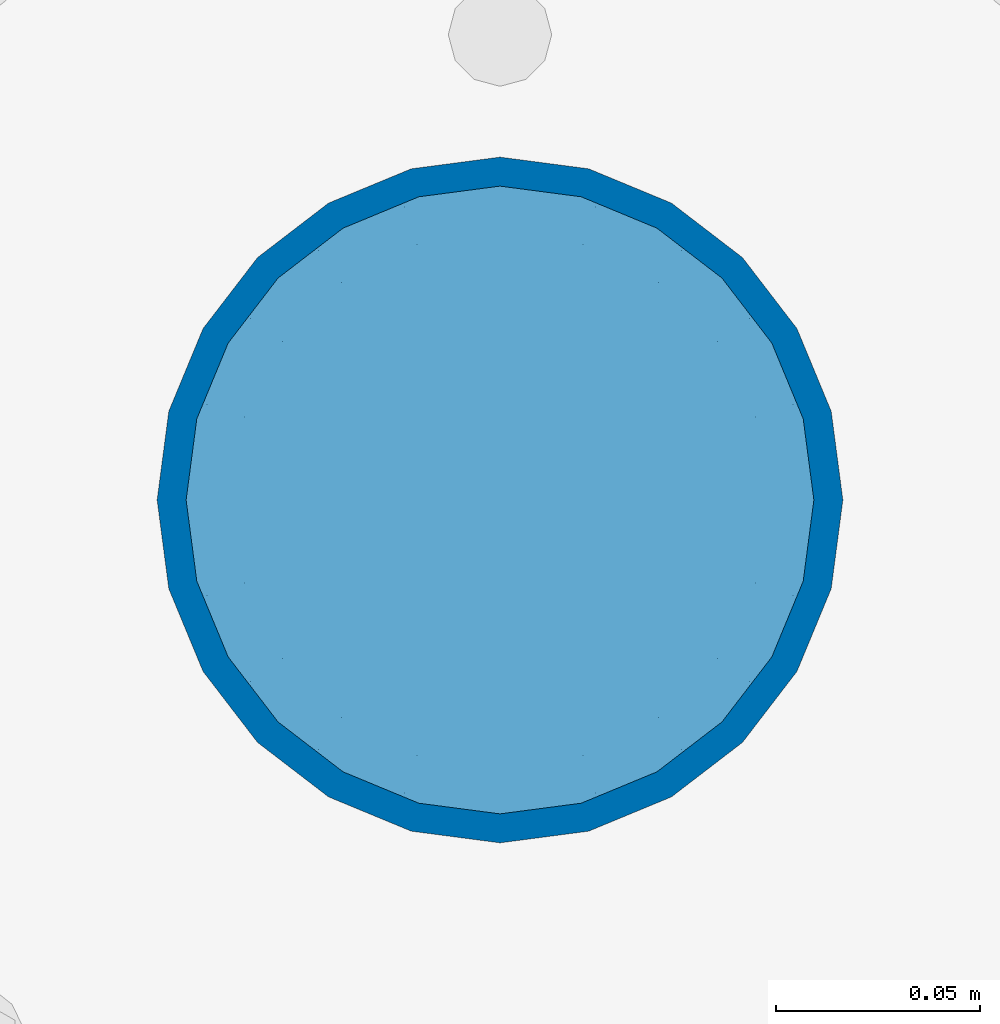
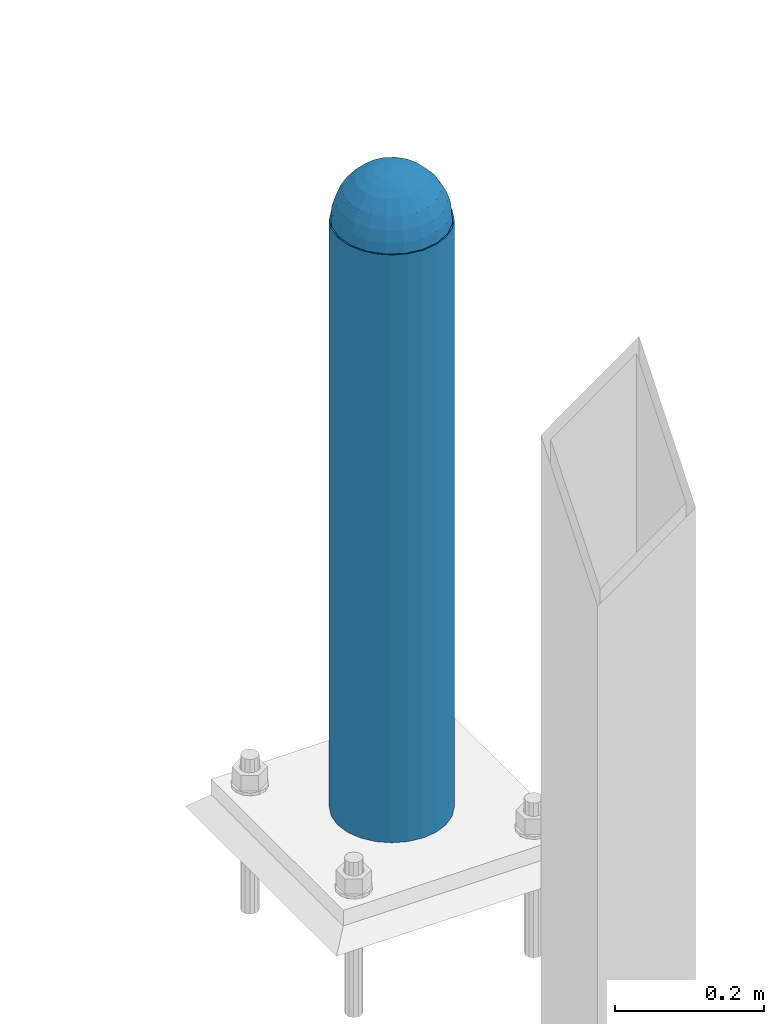
# One storey, part 1591 of 3843: 2 columns, 2 elements without a shape of their own.
"""IFC2X3 building model written with IfcOpenShell, lengths in millimetres."""

import ifcopenshell
import ifcopenshell.guid

model = None  # the IFC model being written
_history = None  # IfcOwnerHistory: only IFC2X3 demands one
_inside = {}  # id of a spatial element -> (the spatial element, [elements in it])
_under = {}  # id of a project, library or spatial element -> (it, [spatial elements below it])
_declared = {}  # id of a project -> (the project, [libraries it declares])
_typed = {}  # id of a type object -> (the type object, [elements of that type])
_made_of = {}  # id of a material, layer set ... -> (it, [elements and type objects made of it])


def new_model(schema):
    """Start an empty IFC model of exactly this schema.

    Asked for "IFC4X3", IfcOpenShell would pick the latest addendum, in which some entities
    have other attributes; the version numbers below select the first issue.
    IFC2X3 requires an IfcOwnerHistory on every rooted entity: one is made here for all.
    """
    global model, _history
    if schema == "IFC4X3":
        model = ifcopenshell.file(schema_version=(4, 3, 0, 0))
    else:
        model = ifcopenshell.file(schema=schema)
    _inside.clear()
    _under.clear()
    _declared.clear()
    _typed.clear()
    _made_of.clear()
    _history = None
    if model.schema == "IFC2X3":
        org = make("IfcOrganization", Name="unknown")
        user = make(
            "IfcPersonAndOrganization",
            ThePerson=make("IfcPerson", FamilyName="unknown"),
            TheOrganization=org,
        )
        app = make(
            "IfcApplication",
            ApplicationDeveloper=org,
            Version="unknown",
            ApplicationFullName="unknown",
            ApplicationIdentifier="unknown",
        )
        _history = make(
            "IfcOwnerHistory",
            OwningUser=user,
            OwningApplication=app,
            ChangeAction="ADDED",
            CreationDate=0,
        )
    return model


def make(cls, **values):
    """One entity of the class cls with the attributes given. An attribute that is None is left unset."""
    return model.create_entity(
        cls, **{name: value for name, value in values.items() if value is not None}
    )


def rooted(cls, **values):
    """An entity with a GlobalId (a new one), such as an element, a storey or a relation."""
    return make(cls, GlobalId=ifcopenshell.guid.new(), OwnerHistory=_history, **values)


def si_unit(unit_type, name, prefix=None):
    """IfcSIUnit, for example si_unit("LENGTHUNIT", "METRE", prefix="MILLI")."""
    return make("IfcSIUnit", UnitType=unit_type, Prefix=prefix, Name=name)


def assignment(units):
    """IfcUnitAssignment: the units of a project."""
    return None if units is None else make("IfcUnitAssignment", Units=units)


def point(xyz):
    """IfcCartesianPoint."""
    return None if xyz is None else make("IfcCartesianPoint", Coordinates=xyz)


def direction(xyz):
    """IfcDirection."""
    return None if xyz is None else make("IfcDirection", DirectionRatios=xyz)


def frame(location, z_axis=None, x_axis=None):
    """IfcAxis2Placement3D, a coordinate frame: its origin and axes. An axis left out is left unset."""
    return make(
        "IfcAxis2Placement3D",
        Location=point(location),
        Axis=direction(z_axis),
        RefDirection=direction(x_axis),
    )


def origin_with_axes():
    """The frame at (0, 0, 0) with the z axis (0, 0, 1) and the x axis (1, 0, 0) written out."""
    return frame((0.0, 0.0, 0.0), z_axis=(0.0, 0.0, 1.0), x_axis=(1.0, 0.0, 0.0))


def place(relative_to, where):
    """IfcLocalPlacement: puts the frame where relative to a parent placement (None: the world)."""
    return make(
        "IfcLocalPlacement", PlacementRelTo=relative_to, RelativePlacement=where
    )


def context(
    kind, dimensions, precision=None, world=None, true_north=None, identifier=None
):
    """IfcGeometricRepresentationContext, for example the 3D "Model" context."""
    return make(
        "IfcGeometricRepresentationContext",
        ContextIdentifier=identifier,
        ContextType=kind,
        CoordinateSpaceDimension=dimensions,
        Precision=precision,
        WorldCoordinateSystem=world,
        TrueNorth=true_north,
    )


def subcontext(parent, identifier, kind, view, scale=None):
    """IfcGeometricRepresentationSubContext, for example "Body" below "Model"."""
    return make(
        "IfcGeometricRepresentationSubContext",
        ContextIdentifier=identifier,
        ContextType=kind,
        ParentContext=parent,
        TargetScale=scale,
        TargetView=view,
    )


def project(units=None, contexts=None):
    """IfcProject with its units and contexts."""
    return rooted(
        "IfcProject",
        Name="project",
        RepresentationContexts=contexts,
        UnitsInContext=assignment(units),
    )


def spatial(cls, under=None, at=None, **own):
    """A site, building, storey or space (cls), placed at a placement, below another one or the project."""
    s = rooted(cls, ObjectPlacement=at, **own)
    if under is not None:
        _under.setdefault(under.id(), (under, []))[1].append(s)
    return s


def faces_of(points, faces, orient=None, outer=None):
    """IfcFace entities. A face is a list of loops; a loop is a list of indices into points, from 0.

    orient and outer hold one flag for each loop. By default every Orientation is true, the
    first loop of a face is its IfcFaceOuterBound and the others are IfcFaceBound.
    """
    made = []
    for i, loops in enumerate(faces):
        bounds = []
        for j, loop in enumerate(loops):
            is_outer = j == 0 if outer is None else outer[i][j]
            bounds.append(
                make(
                    "IfcFaceOuterBound" if is_outer else "IfcFaceBound",
                    Bound=make("IfcPolyLoop", Polygon=[points[k] for k in loop]),
                    Orientation=True if orient is None else orient[i][j],
                )
            )
        made.append(make("IfcFace", Bounds=bounds))
    return made


def faceted_brep(points, faces, orient=None, outer=None, voids=None):
    """IfcFacetedBrep: a solid bounded by flat faces; with voids (closed shells), ...WithVoids."""
    shared = [point(p) for p in points]
    hull = make("IfcClosedShell", CfsFaces=faces_of(shared, faces, orient, outer))
    if voids is None:
        return make("IfcFacetedBrep", Outer=hull)
    return make(
        "IfcFacetedBrepWithVoids",
        Outer=hull,
        Voids=[
            make(cls, CfsFaces=faces_of(shared, fs, o, b)) for cls, fs, o, b in voids
        ],
    )


def shape(context_of_items, identifier, shape_type, items):
    """IfcShapeRepresentation: the items that make up one representation, for example the "Body"."""
    return make(
        "IfcShapeRepresentation",
        ContextOfItems=context_of_items,
        RepresentationIdentifier=identifier,
        RepresentationType=shape_type,
        Items=items,
    )


def material(Name=None, Category=None):
    """IfcMaterial."""
    return make("IfcMaterial", Name=Name, Category=Category)


def made_of(thing, what):
    """Note that an element or type object is made of a material, layer set ...; save() writes the relation."""
    if what is not None:
        _made_of.setdefault(what.id(), (what, []))[1].append(thing)
    return thing


def type_object(cls, material=None, **own):
    """A type object (cls), such as IfcWallType, which elements share."""
    return made_of(rooted(cls, **own), material)


def element(
    cls,
    number,
    at=None,
    inside=None,
    cuts=None,
    type_object=None,
    material=None,
    context=None,
    identifier="Body",
    shape_type=None,
    held_by="IfcProductDefinitionShape",
    body=None,
    shapes=None,
    **own,
):
    """One element of the class cls, such as IfcWall. Its Tag is "e" and its number.

    at: its placement. inside: the storey or other place that contains it. cuts: it is an
    opening in that element (IfcRelVoidsElement). A single representation is given by context,
    identifier, shape_type and body (its items); several are given by shapes. held_by: the class
    of the entity that holds the representations. save() writes the other relations.
    """
    e = rooted(cls, Tag="e%d" % number, ObjectPlacement=at, **own)
    if body is not None:
        shapes = [shape(context, identifier, shape_type, body)]
    if shapes is not None:
        e.Representation = make(held_by, Representations=shapes)
    if inside is not None:
        _inside.setdefault(inside.id(), (inside, []))[1].append(e)
    if cuts is not None:
        rooted(
            "IfcRelVoidsElement", RelatingBuildingElement=cuts, RelatedOpeningElement=e
        )
    if type_object is not None:
        _typed.setdefault(type_object.id(), (type_object, []))[1].append(e)
    return made_of(e, material)


def aggregate(whole, parts):
    """IfcRelAggregates: a whole, such as a stair, and the parts it consists of."""
    return rooted("IfcRelAggregates", RelatingObject=whole, RelatedObjects=parts)


def save(model, path):
    """Write the relations noted so far, then the file.

    IfcRelAggregates (storeys below a building ...), IfcRelContainedInSpatialStructure (elements
    in a storey), IfcRelDefinesByType, IfcRelAssociatesMaterial and IfcRelDeclares: one each for
    every whole, place, type object, material and project.
    """
    for whole, parts in _under.values():
        aggregate(whole, parts)
    for where, things in _inside.values():
        rooted(
            "IfcRelContainedInSpatialStructure",
            RelatedElements=things,
            RelatingStructure=where,
        )
    for kind, things in _typed.values():
        rooted("IfcRelDefinesByType", RelatedObjects=things, RelatingType=kind)
    for what, things in _made_of.values():
        rooted("IfcRelAssociatesMaterial", RelatedObjects=things, RelatingMaterial=what)
    for by, libraries in _declared.values():
        rooted("IfcRelDeclares", RelatingContext=by, RelatedDefinitions=libraries)
    model.write(path)


model = new_model("IFC2X3")

# Units and contexts
model_context = context("Model", 3, precision=1e-05, world=origin_with_axes())
body_context = subcontext(model_context, "Body", "Model", "MODEL_VIEW")
ifc_project = project(units=[si_unit("LENGTHUNIT", "METRE", prefix="MILLI"), si_unit("AREAUNIT", "SQUARE_METRE"), si_unit("VOLUMEUNIT", "CUBIC_METRE"), si_unit("MASSUNIT", "GRAM", prefix="KILO"), si_unit("TIMEUNIT", "SECOND"), si_unit("PLANEANGLEUNIT", "RADIAN"), si_unit("SOLIDANGLEUNIT", "STERADIAN"), si_unit("THERMODYNAMICTEMPERATUREUNIT", "DEGREE_CELSIUS"), si_unit("LUMINOUSINTENSITYUNIT", "LUMEN")], contexts=[model_context])

# Site, building, storey
site_placement = place(None, origin_with_axes())
site = spatial("IfcSite", under=ifc_project, at=site_placement, CompositionType="ELEMENT")
building_placement = place(site_placement, origin_with_axes())
building = spatial("IfcBuilding", under=site, at=building_placement, Name="Undefined", CompositionType="ELEMENT")
storey_placement = place(building_placement, origin_with_axes())
storey = spatial("IfcBuildingStorey", under=building, at=storey_placement, Name="Undefined", CompositionType="ELEMENT", Elevation=0.0)

# Assembly, column
assembly_1_placement = place(storey_placement, origin_with_axes())
assembly_1 = element("IfcElementAssembly", 1, at=assembly_1_placement, inside=storey, Name="CONC. FILL", AssemblyPlace="NOTDEFINED", PredefinedType="REINFORCEMENT_UNIT")
ifc_material_1 = material(Name="CONCRETE/1500")
column_type_1 = type_object("IfcColumnType", PredefinedType="NOTDEFINED")
column_1_placement = place(assembly_1_placement, frame((63957.2, 93129.1, 31411.8625), z_axis=(-1.0, 0.0, 0.0), x_axis=(0.0, 0.0, 1.0)))
column_1 = element("IfcColumn", 2, at=column_1_placement, type_object=column_type_1, material=ifc_material_1, Name="CONC. FILL", context=body_context, shape_type="Brep", body=[
    faceted_brep([(0.0, 0.0, 2.0), (0.0, -0.619999999995343, 1.89999999999964), (3.36549999999988, -7.1422259999963, 21.9814139999999), (3.36549999999988, 0.0, 23.1139999999996), (0.0, -1.17999999999302, 1.6200000000008), (3.36549999999988, -13.5910319999966, 18.6992260000006), (0.0, -1.61999999999534, 1.18000000000029), (3.36549999999988, -18.699225999997, 13.5910320000003), (0.0, -1.89999999999418, 0.6200000000008), (3.36549999999988, -21.9814139999944, 7.14222599999994), (0.0, -2.0, 0.0), (3.36549999999988, -23.1140000000014, 0.0), (0.0, -1.89999999999418, -0.6200000000008), (3.36549999999988, -21.9814139999944, -7.14222599999994), (0.0, -1.61999999999534, -1.18000000000029), (3.36549999999988, -18.699225999997, -13.5910320000003), (0.0, -1.17999999999302, -1.6200000000008), (3.36549999999988, -13.5910319999966, -18.6992260000006), (0.0, -0.619999999995343, -1.89999999999964), (3.36549999999988, -7.1422259999963, -21.9814139999999), (0.0, 0.0, -2.0), (3.36549999999988, 0.0, -23.1139999999996), (0.0, 0.619999999995343, -1.89999999999964), (3.36549999999988, 7.1422259999963, -21.9814139999999), (0.0, 1.17999999999302, -1.6200000000008), (3.36549999999988, 13.5910319999966, -18.6992260000006), (0.0, 1.61999999999534, -1.18000000000029), (3.36549999999988, 18.699225999997, -13.5910320000003), (0.0, 1.89999999999418, -0.6200000000008), (3.36549999999988, 21.9814139999944, -7.14222599999994), (0.0, 2.0, 0.0), (3.36549999999988, 23.1140000000014, 0.0), (0.0, 1.89999999999418, 0.6200000000008), (3.36549999999988, 21.9814139999944, 7.14222599999994), (0.0, 1.61999999999534, 1.18000000000029), (3.36549999999988, 18.699225999997, 13.5910320000003), (0.0, 1.17999999999302, 1.6200000000008), (3.36549999999988, 13.5910319999966, 18.6992260000006), (0.0, 0.619999999995343, 1.89999999999964), (3.36549999999988, 7.1422259999963, 21.9814139999999), (8.41374999999971, -11.1214661999984, 34.2282018000005), (8.41374999999971, 0.0, 35.9917999999998), (8.41374999999971, -21.1631784000056, 29.1173662000001), (8.41374999999971, -29.1173661999928, 21.1631784000001), (8.41374999999971, -34.2282017999969, 11.1214662000002), (8.41374999999971, -35.9918000000034, 0.0), (8.41374999999971, -34.2282017999969, -11.1214662000002), (8.41374999999971, -29.1173661999928, -21.1631784000001), (8.41374999999971, -21.1631784000056, -29.1173662000001), (8.41374999999971, -11.1214661999984, -34.2282018000005), (8.41374999999971, 0.0, -35.9917999999998), (8.41374999999971, 11.1214661999984, -34.2282018000005), (8.41374999999971, 21.1631784000056, -29.1173662000001), (8.41374999999971, 29.1173661999928, -21.1631784000001), (8.41374999999971, 34.2282017999969, -11.1214662000002), (8.41374999999971, 35.9918000000034, 0.0), (8.41374999999971, 34.2282017999969, 11.1214662000002), (8.41374999999971, 29.1173661999928, 21.1631784000001), (8.41374999999971, 21.1631784000056, 29.1173662000001), (8.41374999999971, 11.1214661999984, 34.2282018000005), (16.8274999999994, -15.3047700000025, 47.1030300000002), (16.8274999999994, 0.0, 49.5300000000007), (16.8274999999994, -29.1236400000053, 40.0697700000001), (16.8274999999994, -40.0697700000019, 29.1236399999998), (16.8274999999994, -47.1030299999984, 15.3047700000006), (16.8274999999994, -49.5299999999988, 0.0), (16.8274999999994, -47.1030299999984, -15.3047700000006), (16.8274999999994, -40.0697700000019, -29.1236399999998), (16.8274999999994, -29.1236400000053, -40.0697700000001), (16.8274999999994, -15.3047700000025, -47.1030300000002), (16.8274999999994, 0.0, -49.5300000000007), (16.8274999999994, 15.3047700000025, -47.1030300000002), (16.8274999999994, 29.1236400000053, -40.0697700000001), (16.8274999999994, 40.0697700000019, -29.1236399999998), (16.8274999999994, 47.1030299999984, -15.3047700000006), (16.8274999999994, 49.5299999999988, 0.0), (16.8274999999994, 47.1030299999984, 15.3047700000006), (16.8274999999994, 40.0697700000019, 29.1236399999998), (16.8274999999994, 29.1236400000053, 40.0697700000001), (16.8274999999994, 15.3047700000025, 47.1030300000002), (33.6549999999988, -20.4063599999936, 62.8040400000009), (33.6549999999988, 0.0, 66.0400000000009), (33.6549999999988, -38.831520000007, 53.4263599999995), (33.6549999999988, -53.4263599999977, 38.8315199999997), (33.6549999999988, -62.8040400000027, 20.4063600000009), (33.6549999999988, -66.0399999999936, 0.0), (33.6549999999988, -62.8040400000027, -20.4063600000009), (33.6549999999988, -53.4263599999977, -38.8315199999997), (33.6549999999988, -38.831520000007, -53.4263599999995), (33.6549999999988, -20.4063599999936, -62.8040400000009), (33.6549999999988, 0.0, -66.0400000000009), (33.6549999999988, 20.4063599999936, -62.8040400000009), (33.6549999999988, 38.831520000007, -53.4263599999995), (33.6549999999988, 53.4263599999977, -38.8315199999997), (33.6549999999988, 62.8040400000027, -20.4063600000009), (33.6549999999988, 66.0399999999936, 0.0), (33.6549999999988, 62.8040400000027, 20.4063600000009), (33.6549999999988, 53.4263599999977, 38.8315199999997), (33.6549999999988, 38.831520000007, 53.4263599999995), (33.6549999999988, 20.4063599999936, 62.8040400000009), (50.4824999999983, -23.3907901500061, 71.9891308499991), (50.4824999999983, 0.0, 75.6983500000006), (50.4824999999983, -44.5106298000028, 61.23996515), (50.4824999999983, -61.2399651500018, 44.5106297999992), (50.4824999999983, -71.9891308499937, 23.3907901500006), (50.4824999999983, -75.698350000006, 0.0), (50.4824999999983, -71.9891308499937, -23.3907901500006), (50.4824999999983, -61.2399651500018, -44.5106297999992), (50.4824999999983, -44.5106298000028, -61.23996515), (50.4824999999983, -23.3907901500061, -71.9891308499991), (50.4824999999983, 0.0, -75.6983500000006), (50.4824999999983, 23.3907901500061, -71.9891308499991), (50.4824999999983, 44.5106298000028, -61.23996515), (50.4824999999983, 61.2399651500018, -44.5106297999992), (50.4824999999983, 71.9891308499937, -23.3907901500006), (50.4824999999983, 75.698350000006, 0.0), (50.4824999999983, 71.9891308499937, 23.3907901500006), (50.4824999999983, 61.2399651500018, 44.5106297999992), (50.4824999999983, 44.5106298000028, 61.23996515), (50.4824999999983, 23.3907901500061, 71.9891308499991), (67.3099999999977, -24.9977910000016, 76.9349490000004), (67.3099999999977, 0.0, 80.8989999999994), (67.3099999999977, -47.5686120000028, 65.4472910000004), (67.3099999999977, -65.447291000004, 47.5686119999991), (67.3099999999977, -76.9349490000022, 24.9977909999998), (67.3099999999977, -80.8990000000049, 0.0), (67.3099999999977, -76.9349490000022, -24.9977909999998), (67.3099999999977, -65.447291000004, -47.5686119999991), (67.3099999999977, -47.5686120000028, -65.4472910000004), (67.3099999999977, -24.9977910000016, -76.9349490000004), (67.3099999999977, 0.0, -80.8989999999994), (67.3099999999977, 24.9977910000016, -76.9349490000004), (67.3099999999977, 47.5686120000028, -65.4472910000004), (67.3099999999977, 65.447291000004, -47.5686119999991), (67.3099999999977, 76.9349490000022, -24.9977909999998), (67.3099999999977, 80.8990000000049, 0.0), (67.3099999999977, 76.9349490000022, 24.9977909999998), (67.3099999999977, 65.447291000004, 47.5686119999991), (67.3099999999977, 47.5686120000028, 65.4472910000004), (67.3099999999977, 24.9977910000016, 76.9349490000004), (84.1374999999935, -25.5079499999993, 78.5050499999998), (84.1374999999935, 0.0, 82.5499999999993), (84.1374999999935, -48.5393999999942, 66.7829500000007), (84.1374999999935, -66.7829499999934, 48.5393999999997), (84.1374999999935, -78.505050000007, 25.5079499999993), (84.1374999999935, -82.5500000000029, 0.0), (84.1374999999935, -78.505050000007, -25.5079499999993), (84.1374999999935, -66.7829499999934, -48.5393999999997), (84.1374999999935, -48.5393999999942, -66.7829500000007), (84.1374999999935, -25.5079499999993, -78.5050499999998), (84.1374999999935, 0.0, -82.5499999999993), (84.1374999999935, 25.5079499999993, -78.5050499999998), (84.1374999999935, 48.5393999999942, -66.7829500000007), (84.1374999999935, 66.7829499999934, -48.5393999999997), (84.1374999999935, 78.505050000007, -25.5079499999993), (84.1374999999935, 82.5500000000029, 0.0), (84.1374999999935, 78.505050000007, 25.5079499999993), (84.1374999999935, 66.7829499999934, 48.5393999999997), (84.1374999999935, 48.5393999999942, 66.7829500000007), (84.1374999999935, 25.5079499999993, 78.5050499999998), (100.964999999993, -24.9977910000016, 76.9349490000004), (100.964999999993, 0.0, 80.8989999999994), (100.964999999993, -47.5686120000028, 65.4472910000004), (100.964999999993, -65.447291000004, 47.5686119999991), (100.964999999993, -76.9349490000022, 24.9977909999998), (100.964999999993, -80.8990000000049, 0.0), (100.964999999993, -76.9349490000022, -24.9977909999998), (100.964999999993, -65.447291000004, -47.5686119999991), (100.964999999993, -47.5686120000028, -65.4472910000004), (100.964999999993, -24.9977910000016, -76.9349490000004), (100.964999999993, 0.0, -80.8989999999994), (100.964999999993, 24.9977910000016, -76.9349490000004), (100.964999999993, 47.5686120000028, -65.4472910000004), (100.964999999993, 65.447291000004, -47.5686119999991), (100.964999999993, 76.9349490000022, -24.9977909999998), (100.964999999993, 80.8990000000049, 0.0), (100.964999999993, 76.9349490000022, 24.9977909999998), (100.964999999993, 65.447291000004, 47.5686119999991), (100.964999999993, 47.5686120000028, 65.4472910000004), (100.964999999993, 24.9977910000016, 76.9349490000004), (117.792499999992, -23.3907901500061, 71.9891308499991), (117.792499999992, 0.0, 75.6983500000006), (117.792499999992, -44.5106298000028, 61.23996515), (117.792499999992, -61.2399651500018, 44.5106297999992), (117.792499999992, -71.9891308499937, 23.3907901500006), (117.792499999992, -75.698350000006, 0.0), (117.792499999992, -71.9891308499937, -23.3907901500006), (117.792499999992, -61.2399651500018, -44.5106297999992), (117.792499999992, -44.5106298000028, -61.23996515), (117.792499999992, -23.3907901500061, -71.9891308499991), (117.792499999992, 0.0, -75.6983500000006), (117.792499999992, 23.3907901500061, -71.9891308499991), (117.792499999992, 44.5106298000028, -61.23996515), (117.792499999992, 61.2399651500018, -44.5106297999992), (117.792499999992, 71.9891308499937, -23.3907901500006), (117.792499999992, 75.698350000006, 0.0), (117.792499999992, 71.9891308499937, 23.3907901500006), (117.792499999992, 61.2399651500018, 44.5106297999992), (117.792499999992, 44.5106298000028, 61.23996515), (117.792499999992, 23.3907901500061, 71.9891308499991), (134.619999999992, -20.4063599999936, 62.8040400000009), (134.619999999992, 0.0, 66.0400000000009), (134.619999999992, -38.831520000007, 53.4263599999995), (134.619999999992, -53.4263599999977, 38.8315199999997), (134.619999999992, -62.8040400000027, 20.4063600000009), (134.619999999992, -66.0399999999936, 0.0), (134.619999999992, -62.8040400000027, -20.4063600000009), (134.619999999992, -53.4263599999977, -38.8315199999997), (134.619999999992, -38.831520000007, -53.4263599999995), (134.619999999992, -20.4063599999936, -62.8040400000009), (134.619999999992, 0.0, -66.0400000000009), (134.619999999992, 20.4063599999936, -62.8040400000009), (134.619999999992, 38.831520000007, -53.4263599999995), (134.619999999992, 53.4263599999977, -38.8315199999997), (134.619999999992, 62.8040400000027, -20.4063600000009), (134.619999999992, 66.0399999999936, 0.0), (134.619999999992, 62.8040400000027, 20.4063600000009), (134.619999999992, 53.4263599999977, 38.8315199999997), (134.619999999992, 38.831520000007, 53.4263599999995), (134.619999999992, 20.4063599999936, 62.8040400000009), (151.447499999991, -15.3047700000025, 47.1030300000002), (151.447499999991, 0.0, 49.5300000000007), (151.447499999991, -29.1236400000053, 40.0697700000001), (151.447499999991, -40.0697700000019, 29.1236399999998), (151.447499999991, -47.1030299999984, 15.3047700000006), (151.447499999991, -49.5299999999988, 0.0), (151.447499999991, -47.1030299999984, -15.3047700000006), (151.447499999991, -40.0697700000019, -29.1236399999998), (151.447499999991, -29.1236400000053, -40.0697700000001), (151.447499999991, -15.3047700000025, -47.1030300000002), (151.447499999991, 0.0, -49.5300000000007), (151.447499999991, 15.3047700000025, -47.1030300000002), (151.447499999991, 29.1236400000053, -40.0697700000001), (151.447499999991, 40.0697700000019, -29.1236399999998), (151.447499999991, 47.1030299999984, -15.3047700000006), (151.447499999991, 49.5299999999988, 0.0), (151.447499999991, 47.1030299999984, 15.3047700000006), (151.447499999991, 40.0697700000019, 29.1236399999998), (151.447499999991, 29.1236400000053, 40.0697700000001), (151.447499999991, 15.3047700000025, 47.1030300000002), (159.861249999991, -11.1214661999984, 34.2282018000005), (159.861249999991, 0.0, 35.9917999999998), (159.861249999991, -21.1631784000056, 29.1173662000001), (159.861249999991, -29.1173661999928, 21.1631784000001), (159.861249999991, -34.2282017999969, 11.1214662000002), (159.861249999991, -35.9918000000034, 0.0), (159.861249999991, -34.2282017999969, -11.1214662000002), (159.861249999991, -29.1173661999928, -21.1631784000001), (159.861249999991, -21.1631784000056, -29.1173662000001), (159.861249999991, -11.1214661999984, -34.2282018000005), (159.861249999991, 0.0, -35.9917999999998), (159.861249999991, 11.1214661999984, -34.2282018000005), (159.861249999991, 21.1631784000056, -29.1173662000001), (159.861249999991, 29.1173661999928, -21.1631784000001), (159.861249999991, 34.2282017999969, -11.1214662000002), (159.861249999991, 35.9918000000034, 0.0), (159.861249999991, 34.2282017999969, 11.1214662000002), (159.861249999991, 29.1173661999928, 21.1631784000001), (159.861249999991, 21.1631784000056, 29.1173662000001), (159.861249999991, 11.1214661999984, 34.2282018000005), (164.909499999991, -7.1422259999963, 21.9814139999999), (164.909499999991, 0.0, 23.1139999999996), (164.909499999991, -13.5910319999966, 18.6992260000006), (164.909499999991, -18.699225999997, 13.5910320000003), (164.909499999991, -21.9814139999944, 7.14222599999994), (164.909499999991, -23.1140000000014, 0.0), (164.909499999991, -21.9814139999944, -7.14222599999994), (164.909499999991, -18.699225999997, -13.5910320000003), (164.909499999991, -13.5910319999966, -18.6992260000006), (164.909499999991, -7.1422259999963, -21.9814139999999), (164.909499999991, 0.0, -23.1139999999996), (164.909499999991, 7.1422259999963, -21.9814139999999), (164.909499999991, 13.5910319999966, -18.6992260000006), (164.909499999991, 18.699225999997, -13.5910320000003), (164.909499999991, 21.9814139999944, -7.14222599999994), (164.909499999991, 23.1140000000014, 0.0), (164.909499999991, 21.9814139999944, 7.14222599999994), (164.909499999991, 18.699225999997, 13.5910320000003), (164.909499999991, 13.5910319999966, 18.6992260000006), (164.909499999991, 7.1422259999963, 21.9814139999999), (168.274999999991, -0.619999999995343, 1.89999999999964), (168.274999999991, 0.0, 2.0), (168.274999999991, -1.17999999999302, 1.6200000000008), (168.274999999991, -1.61999999999534, 1.18000000000029), (168.274999999991, -1.89999999999418, 0.6200000000008), (168.274999999991, -2.0, 0.0), (168.274999999991, -1.89999999999418, -0.6200000000008), (168.274999999991, -1.61999999999534, -1.18000000000029), (168.274999999991, -1.17999999999302, -1.6200000000008), (168.274999999991, -0.619999999995343, -1.89999999999964), (168.274999999991, 0.0, -2.0), (168.274999999991, 0.619999999995343, -1.89999999999964), (168.274999999991, 1.17999999999302, -1.6200000000008), (168.274999999991, 1.61999999999534, -1.18000000000029), (168.274999999991, 1.89999999999418, -0.6200000000008), (168.274999999991, 2.0, 0.0), (168.274999999991, 1.89999999999418, 0.6200000000008), (168.274999999991, 1.61999999999534, 1.18000000000029), (168.274999999991, 1.17999999999302, 1.6200000000008), (168.274999999991, 0.619999999995343, 1.89999999999964)], [[[0, 1, 2, 3]], [[1, 4, 5, 2]], [[4, 6, 7, 5]], [[6, 8, 9, 7]], [[8, 10, 11, 9]], [[10, 12, 13, 11]], [[12, 14, 15, 13]], [[14, 16, 17, 15]], [[16, 18, 19, 17]], [[18, 20, 21, 19]], [[20, 22, 23, 21]], [[22, 24, 25, 23]], [[24, 26, 27, 25]], [[26, 28, 29, 27]], [[28, 30, 31, 29]], [[30, 32, 33, 31]], [[32, 34, 35, 33]], [[34, 36, 37, 35]], [[36, 38, 39, 37]], [[38, 0, 3, 39]], [[38, 36, 34, 32, 30, 28, 26, 24, 22, 20, 18, 16, 14, 12, 10, 8, 6, 4, 1, 0]], [[3, 2, 40, 41]], [[2, 5, 42, 40]], [[5, 7, 43, 42]], [[7, 9, 44, 43]], [[9, 11, 45, 44]], [[11, 13, 46, 45]], [[13, 15, 47, 46]], [[15, 17, 48, 47]], [[17, 19, 49, 48]], [[19, 21, 50, 49]], [[21, 23, 51, 50]], [[23, 25, 52, 51]], [[25, 27, 53, 52]], [[27, 29, 54, 53]], [[29, 31, 55, 54]], [[31, 33, 56, 55]], [[33, 35, 57, 56]], [[35, 37, 58, 57]], [[37, 39, 59, 58]], [[39, 3, 41, 59]], [[41, 40, 60, 61]], [[40, 42, 62, 60]], [[42, 43, 63, 62]], [[43, 44, 64, 63]], [[44, 45, 65, 64]], [[45, 46, 66, 65]], [[46, 47, 67, 66]], [[47, 48, 68, 67]], [[48, 49, 69, 68]], [[49, 50, 70, 69]], [[50, 51, 71, 70]], [[51, 52, 72, 71]], [[52, 53, 73, 72]], [[53, 54, 74, 73]], [[54, 55, 75, 74]], [[55, 56, 76, 75]], [[56, 57, 77, 76]], [[57, 58, 78, 77]], [[58, 59, 79, 78]], [[59, 41, 61, 79]], [[61, 60, 80, 81]], [[60, 62, 82, 80]], [[62, 63, 83, 82]], [[63, 64, 84, 83]], [[64, 65, 85, 84]], [[65, 66, 86, 85]], [[66, 67, 87, 86]], [[67, 68, 88, 87]], [[68, 69, 89, 88]], [[69, 70, 90, 89]], [[70, 71, 91, 90]], [[71, 72, 92, 91]], [[72, 73, 93, 92]], [[73, 74, 94, 93]], [[74, 75, 95, 94]], [[75, 76, 96, 95]], [[76, 77, 97, 96]], [[77, 78, 98, 97]], [[78, 79, 99, 98]], [[79, 61, 81, 99]], [[81, 80, 100, 101]], [[80, 82, 102, 100]], [[82, 83, 103, 102]], [[83, 84, 104, 103]], [[84, 85, 105, 104]], [[85, 86, 106, 105]], [[86, 87, 107, 106]], [[87, 88, 108, 107]], [[88, 89, 109, 108]], [[89, 90, 110, 109]], [[90, 91, 111, 110]], [[91, 92, 112, 111]], [[92, 93, 113, 112]], [[93, 94, 114, 113]], [[94, 95, 115, 114]], [[95, 96, 116, 115]], [[96, 97, 117, 116]], [[97, 98, 118, 117]], [[98, 99, 119, 118]], [[99, 81, 101, 119]], [[101, 100, 120, 121]], [[100, 102, 122, 120]], [[102, 103, 123, 122]], [[103, 104, 124, 123]], [[104, 105, 125, 124]], [[105, 106, 126, 125]], [[106, 107, 127, 126]], [[107, 108, 128, 127]], [[108, 109, 129, 128]], [[109, 110, 130, 129]], [[110, 111, 131, 130]], [[111, 112, 132, 131]], [[112, 113, 133, 132]], [[113, 114, 134, 133]], [[114, 115, 135, 134]], [[115, 116, 136, 135]], [[116, 117, 137, 136]], [[117, 118, 138, 137]], [[118, 119, 139, 138]], [[119, 101, 121, 139]], [[121, 120, 140, 141]], [[120, 122, 142, 140]], [[122, 123, 143, 142]], [[123, 124, 144, 143]], [[124, 125, 145, 144]], [[125, 126, 146, 145]], [[126, 127, 147, 146]], [[127, 128, 148, 147]], [[128, 129, 149, 148]], [[129, 130, 150, 149]], [[130, 131, 151, 150]], [[131, 132, 152, 151]], [[132, 133, 153, 152]], [[133, 134, 154, 153]], [[134, 135, 155, 154]], [[135, 136, 156, 155]], [[136, 137, 157, 156]], [[137, 138, 158, 157]], [[138, 139, 159, 158]], [[139, 121, 141, 159]], [[141, 140, 160, 161]], [[140, 142, 162, 160]], [[142, 143, 163, 162]], [[143, 144, 164, 163]], [[144, 145, 165, 164]], [[145, 146, 166, 165]], [[146, 147, 167, 166]], [[147, 148, 168, 167]], [[148, 149, 169, 168]], [[149, 150, 170, 169]], [[150, 151, 171, 170]], [[151, 152, 172, 171]], [[152, 153, 173, 172]], [[153, 154, 174, 173]], [[154, 155, 175, 174]], [[155, 156, 176, 175]], [[156, 157, 177, 176]], [[157, 158, 178, 177]], [[158, 159, 179, 178]], [[159, 141, 161, 179]], [[161, 160, 180, 181]], [[160, 162, 182, 180]], [[162, 163, 183, 182]], [[163, 164, 184, 183]], [[164, 165, 185, 184]], [[165, 166, 186, 185]], [[166, 167, 187, 186]], [[167, 168, 188, 187]], [[168, 169, 189, 188]], [[169, 170, 190, 189]], [[170, 171, 191, 190]], [[171, 172, 192, 191]], [[172, 173, 193, 192]], [[173, 174, 194, 193]], [[174, 175, 195, 194]], [[175, 176, 196, 195]], [[176, 177, 197, 196]], [[177, 178, 198, 197]], [[178, 179, 199, 198]], [[179, 161, 181, 199]], [[181, 180, 200, 201]], [[180, 182, 202, 200]], [[182, 183, 203, 202]], [[183, 184, 204, 203]], [[184, 185, 205, 204]], [[185, 186, 206, 205]], [[186, 187, 207, 206]], [[187, 188, 208, 207]], [[188, 189, 209, 208]], [[189, 190, 210, 209]], [[190, 191, 211, 210]], [[191, 192, 212, 211]], [[192, 193, 213, 212]], [[193, 194, 214, 213]], [[194, 195, 215, 214]], [[195, 196, 216, 215]], [[196, 197, 217, 216]], [[197, 198, 218, 217]], [[198, 199, 219, 218]], [[199, 181, 201, 219]], [[201, 200, 220, 221]], [[200, 202, 222, 220]], [[202, 203, 223, 222]], [[203, 204, 224, 223]], [[204, 205, 225, 224]], [[205, 206, 226, 225]], [[206, 207, 227, 226]], [[207, 208, 228, 227]], [[208, 209, 229, 228]], [[209, 210, 230, 229]], [[210, 211, 231, 230]], [[211, 212, 232, 231]], [[212, 213, 233, 232]], [[213, 214, 234, 233]], [[214, 215, 235, 234]], [[215, 216, 236, 235]], [[216, 217, 237, 236]], [[217, 218, 238, 237]], [[218, 219, 239, 238]], [[219, 201, 221, 239]], [[221, 220, 240, 241]], [[220, 222, 242, 240]], [[222, 223, 243, 242]], [[223, 224, 244, 243]], [[224, 225, 245, 244]], [[225, 226, 246, 245]], [[226, 227, 247, 246]], [[227, 228, 248, 247]], [[228, 229, 249, 248]], [[229, 230, 250, 249]], [[230, 231, 251, 250]], [[231, 232, 252, 251]], [[232, 233, 253, 252]], [[233, 234, 254, 253]], [[234, 235, 255, 254]], [[235, 236, 256, 255]], [[236, 237, 257, 256]], [[237, 238, 258, 257]], [[238, 239, 259, 258]], [[239, 221, 241, 259]], [[241, 240, 260, 261]], [[240, 242, 262, 260]], [[242, 243, 263, 262]], [[243, 244, 264, 263]], [[244, 245, 265, 264]], [[245, 246, 266, 265]], [[246, 247, 267, 266]], [[247, 248, 268, 267]], [[248, 249, 269, 268]], [[249, 250, 270, 269]], [[250, 251, 271, 270]], [[251, 252, 272, 271]], [[252, 253, 273, 272]], [[253, 254, 274, 273]], [[254, 255, 275, 274]], [[255, 256, 276, 275]], [[256, 257, 277, 276]], [[257, 258, 278, 277]], [[258, 259, 279, 278]], [[259, 241, 261, 279]], [[261, 260, 280, 281]], [[260, 262, 282, 280]], [[262, 263, 283, 282]], [[263, 264, 284, 283]], [[264, 265, 285, 284]], [[265, 266, 286, 285]], [[266, 267, 287, 286]], [[267, 268, 288, 287]], [[268, 269, 289, 288]], [[269, 270, 290, 289]], [[270, 271, 291, 290]], [[271, 272, 292, 291]], [[272, 273, 293, 292]], [[273, 274, 294, 293]], [[274, 275, 295, 294]], [[275, 276, 296, 295]], [[276, 277, 297, 296]], [[277, 278, 298, 297]], [[278, 279, 299, 298]], [[279, 261, 281, 299]], [[282, 283, 284, 285, 286, 287, 288, 289, 290, 291, 292, 293, 294, 295, 296, 297, 298, 299, 281, 280]]]),
])
aggregate(assembly_1, [column_1])

assembly_2_placement = place(storey_placement, origin_with_axes())
assembly_2 = element("IfcElementAssembly", 3, at=assembly_2_placement, inside=storey, Name="PIPE_BOLLARD", AssemblyPlace="NOTDEFINED", PredefinedType="RIGID_FRAME")
ifc_material_2 = material()
column_type_2 = type_object("IfcColumnType", Name="PIPE6SCH40", PredefinedType="NOTDEFINED")
column_2_placement = place(assembly_2_placement, frame((63957.2, 93129.1, 30480.0), z_axis=(-1.0, 0.0, 0.0), x_axis=(0.0, 0.0, 1.0)))
column_2 = element("IfcColumn", 4, at=column_2_placement, type_object=column_type_2, material=ifc_material_2, Name="PIPE_BOLLARD", ObjectType="PIPE6SCH40", context=body_context, shape_type="Brep", body=[
    faceted_brep([(50.7999999999993, -77.0890000000072, 0.0), (50.7999999999993, -74.4622560228017, 19.9521013679114), (1016.0, -74.4622560228017, 19.9521013679114), (1016.0, -77.0890000000072, 0.0), (50.7999999999993, -66.7610323523404, 38.5445000000036), (1016.0, -66.7610323523404, 38.5445000000036), (50.7999999999993, -54.5101546548831, 54.5101546548904), (1016.0, -54.5101546548831, 54.5101546548904), (50.7999999999993, -38.5445000000036, 66.7610323523404), (1016.0, -38.5445000000036, 66.7610323523404), (50.7999999999993, -19.9521013679041, 74.4622560227945), (1016.0, -19.9521013679041, 74.4622560227945), (50.7999999999993, 0.0, 77.0889999999999), (1016.0, 0.0, 77.0889999999999), (50.7999999999993, 19.9521013679041, 74.4622560227945), (1016.0, 19.9521013679041, 74.4622560227945), (50.7999999999993, 38.5445000000036, 66.7610323523404), (1016.0, 38.5445000000036, 66.7610323523404), (50.7999999999993, 54.5101546548831, 54.5101546548904), (1016.0, 54.5101546548831, 54.5101546548904), (50.7999999999993, 66.7610323523404, 38.5445000000036), (1016.0, 66.7610323523404, 38.5445000000036), (50.7999999999993, 74.4622560228017, 19.9521013679114), (1016.0, 74.4622560228017, 19.9521013679114), (50.7999999999993, 77.0890000000072, 0.0), (1016.0, 77.0890000000072, 0.0), (50.7999999999993, 74.4622560228017, -19.9521013679114), (1016.0, 74.4622560228017, -19.9521013679114), (50.7999999999993, 66.7610323523404, -38.5445000000036), (1016.0, 66.7610323523404, -38.5445000000036), (50.7999999999993, 54.5101546548831, -54.5101546548904), (1016.0, 54.5101546548831, -54.5101546548904), (50.7999999999993, 38.5445000000036, -66.7610323523404), (1016.0, 38.5445000000036, -66.7610323523404), (50.7999999999993, 19.9521013679041, -74.4622560227945), (1016.0, 19.9521013679041, -74.4622560227945), (50.7999999999993, 0.0, -77.0889999999999), (1016.0, 0.0, -77.0889999999999), (50.7999999999993, -19.9521013679041, -74.4622560227945), (1016.0, -19.9521013679041, -74.4622560227945), (50.7999999999993, -38.5445000000036, -66.7610323523404), (1016.0, -38.5445000000036, -66.7610323523404), (50.7999999999993, -54.5101546548831, -54.5101546548904), (1016.0, -54.5101546548831, -54.5101546548904), (50.7999999999993, -66.7610323523404, -38.5445000000036), (1016.0, -66.7610323523404, -38.5445000000036), (50.7999999999993, -74.4622560228017, -19.9521013679114), (1016.0, -74.4622560228017, -19.9521013679114), (50.7999999999993, -84.2010000000009, 0.0), (50.7999999999993, -81.3319204993604, -21.7928224166753), (1016.0, -81.3319204993604, -21.7928224166753), (1016.0, -84.2010000000009, 0.0), (50.7999999999993, -72.9202050240565, -42.1005000000005), (1016.0, -72.9202050240565, -42.1005000000005), (50.7999999999993, -59.5390980826924, -59.5390980826851), (1016.0, -59.5390980826924, -59.5390980826851), (50.7999999999993, -42.1005000000005, -72.9202050240565), (1016.0, -42.1005000000005, -72.9202050240565), (50.7999999999993, -21.7928224166826, -81.3319204993677), (1016.0, -21.7928224166826, -81.3319204993677), (50.7999999999993, 0.0, -84.2010000000009), (1016.0, 0.0, -84.2010000000009), (50.7999999999993, 21.7928224166826, -81.3319204993677), (1016.0, 21.7928224166826, -81.3319204993677), (50.7999999999993, 42.1005000000005, -72.9202050240565), (1016.0, 42.1005000000005, -72.9202050240565), (50.7999999999993, 59.5390980826924, -59.5390980826851), (1016.0, 59.5390980826924, -59.5390980826851), (50.7999999999993, 72.9202050240565, -42.1005000000005), (1016.0, 72.9202050240565, -42.1005000000005), (50.7999999999993, 81.3319204993604, -21.7928224166753), (1016.0, 81.3319204993604, -21.7928224166753), (50.7999999999993, 84.2010000000009, 0.0), (1016.0, 84.2010000000009, 0.0), (50.7999999999993, 81.3319204993604, 21.7928224166753), (1016.0, 81.3319204993604, 21.7928224166753), (50.7999999999993, 72.9202050240565, 42.1005000000005), (1016.0, 72.9202050240565, 42.1005000000005), (50.7999999999993, 59.5390980826924, 59.5390980826851), (1016.0, 59.5390980826924, 59.5390980826851), (50.7999999999993, 42.1005000000005, 72.9202050240565), (1016.0, 42.1005000000005, 72.9202050240565), (50.7999999999993, 21.7928224166826, 81.3319204993677), (1016.0, 21.7928224166826, 81.3319204993677), (50.7999999999993, 0.0, 84.2010000000009), (1016.0, 0.0, 84.2010000000009), (50.7999999999993, -21.7928224166826, 81.3319204993677), (1016.0, -21.7928224166826, 81.3319204993677), (50.7999999999993, -42.1005000000005, 72.9202050240565), (1016.0, -42.1005000000005, 72.9202050240565), (50.7999999999993, -59.5390980826924, 59.5390980826851), (1016.0, -59.5390980826924, 59.5390980826851), (50.7999999999993, -72.9202050240565, 42.1005000000005), (1016.0, -72.9202050240565, 42.1005000000005), (50.7999999999993, -81.3319204993604, 21.7928224166753), (1016.0, -81.3319204993604, 21.7928224166753)], [[[0, 1, 2, 3]], [[1, 4, 5, 2]], [[4, 6, 7, 5]], [[6, 8, 9, 7]], [[8, 10, 11, 9]], [[10, 12, 13, 11]], [[12, 14, 15, 13]], [[14, 16, 17, 15]], [[16, 18, 19, 17]], [[18, 20, 21, 19]], [[20, 22, 23, 21]], [[22, 24, 25, 23]], [[24, 26, 27, 25]], [[26, 28, 29, 27]], [[28, 30, 31, 29]], [[30, 32, 33, 31]], [[32, 34, 35, 33]], [[34, 36, 37, 35]], [[36, 38, 39, 37]], [[38, 40, 41, 39]], [[40, 42, 43, 41]], [[42, 44, 45, 43]], [[44, 46, 47, 45]], [[46, 0, 3, 47]], [[48, 49, 50, 51]], [[49, 52, 53, 50]], [[52, 54, 55, 53]], [[54, 56, 57, 55]], [[56, 58, 59, 57]], [[58, 60, 61, 59]], [[60, 62, 63, 61]], [[62, 64, 65, 63]], [[64, 66, 67, 65]], [[66, 68, 69, 67]], [[68, 70, 71, 69]], [[70, 72, 73, 71]], [[72, 74, 75, 73]], [[74, 76, 77, 75]], [[76, 78, 79, 77]], [[78, 80, 81, 79]], [[80, 82, 83, 81]], [[82, 84, 85, 83]], [[84, 86, 87, 85]], [[86, 88, 89, 87]], [[88, 90, 91, 89]], [[90, 92, 93, 91]], [[92, 94, 95, 93]], [[94, 48, 51, 95]], [[53, 55, 57, 59, 61, 63, 65, 67, 69, 71, 73, 75, 77, 79, 81, 83, 85, 87, 89, 91, 93, 95, 51, 50], [5, 7, 9, 11, 13, 15, 17, 19, 21, 23, 25, 27, 29, 31, 33, 35, 37, 39, 41, 43, 45, 47, 3, 2]], [[94, 92, 90, 88, 86, 84, 82, 80, 78, 76, 74, 72, 70, 68, 66, 64, 62, 60, 58, 56, 54, 52, 49, 48], [46, 44, 42, 40, 38, 36, 34, 32, 30, 28, 26, 24, 22, 20, 18, 16, 14, 12, 10, 8, 6, 4, 1, 0]]]),
])
aggregate(assembly_2, [column_2])

save(model, "model.ifc")
